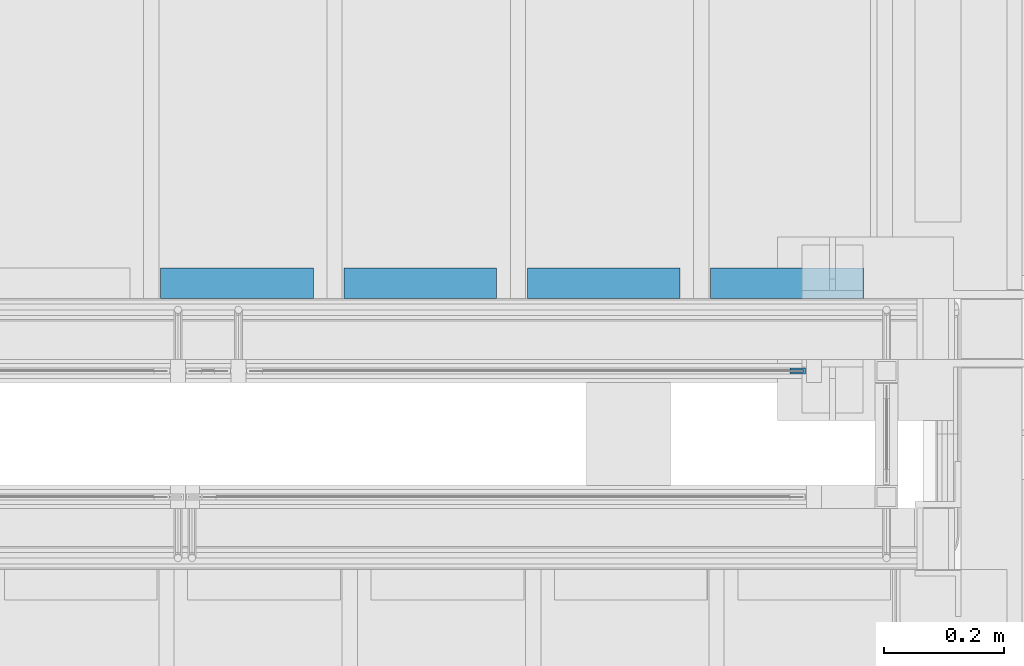
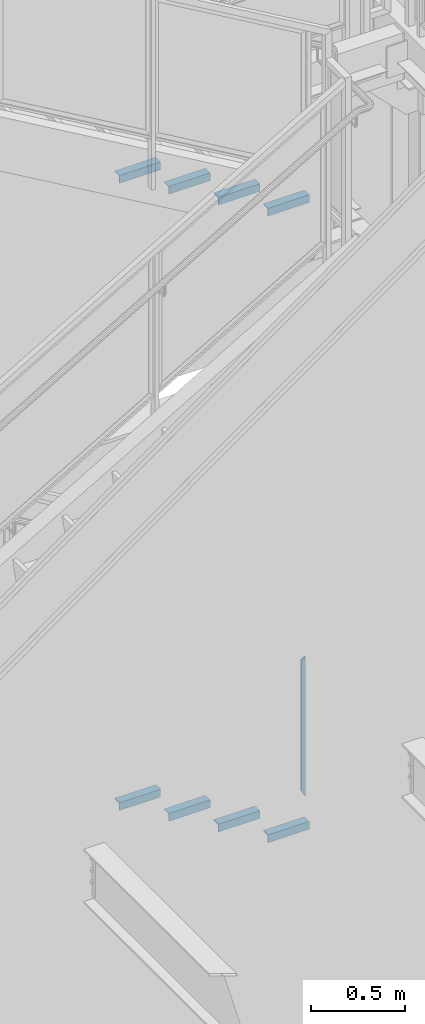
# One storey, part 941 of 1179: 9 beams, 3 elements without a shape of their own.
"""IFC2X3 building model written with IfcOpenShell, lengths in millimetres."""

import ifcopenshell
import ifcopenshell.guid

model = None  # the IFC model being written
_history = None  # IfcOwnerHistory: only IFC2X3 demands one
_inside = {}  # id of a spatial element -> (the spatial element, [elements in it])
_under = {}  # id of a project, library or spatial element -> (it, [spatial elements below it])
_declared = {}  # id of a project -> (the project, [libraries it declares])
_typed = {}  # id of a type object -> (the type object, [elements of that type])
_made_of = {}  # id of a material, layer set ... -> (it, [elements and type objects made of it])


def new_model(schema):
    """Start an empty IFC model of exactly this schema.

    Asked for "IFC4X3", IfcOpenShell would pick the latest addendum, in which some entities
    have other attributes; the version numbers below select the first issue.
    IFC2X3 requires an IfcOwnerHistory on every rooted entity: one is made here for all.
    """
    global model, _history
    if schema == "IFC4X3":
        model = ifcopenshell.file(schema_version=(4, 3, 0, 0))
    else:
        model = ifcopenshell.file(schema=schema)
    _inside.clear()
    _under.clear()
    _declared.clear()
    _typed.clear()
    _made_of.clear()
    _history = None
    if model.schema == "IFC2X3":
        org = make("IfcOrganization", Name="unknown")
        user = make(
            "IfcPersonAndOrganization",
            ThePerson=make("IfcPerson", FamilyName="unknown"),
            TheOrganization=org,
        )
        app = make(
            "IfcApplication",
            ApplicationDeveloper=org,
            Version="unknown",
            ApplicationFullName="unknown",
            ApplicationIdentifier="unknown",
        )
        _history = make(
            "IfcOwnerHistory",
            OwningUser=user,
            OwningApplication=app,
            ChangeAction="ADDED",
            CreationDate=0,
        )
    return model


def make(cls, **values):
    """One entity of the class cls with the attributes given. An attribute that is None is left unset."""
    return model.create_entity(
        cls, **{name: value for name, value in values.items() if value is not None}
    )


def rooted(cls, **values):
    """An entity with a GlobalId (a new one), such as an element, a storey or a relation."""
    return make(cls, GlobalId=ifcopenshell.guid.new(), OwnerHistory=_history, **values)


def si_unit(unit_type, name, prefix=None):
    """IfcSIUnit, for example si_unit("LENGTHUNIT", "METRE", prefix="MILLI")."""
    return make("IfcSIUnit", UnitType=unit_type, Prefix=prefix, Name=name)


def assignment(units):
    """IfcUnitAssignment: the units of a project."""
    return None if units is None else make("IfcUnitAssignment", Units=units)


def point(xyz):
    """IfcCartesianPoint."""
    return None if xyz is None else make("IfcCartesianPoint", Coordinates=xyz)


def direction(xyz):
    """IfcDirection."""
    return None if xyz is None else make("IfcDirection", DirectionRatios=xyz)


def frame(location, z_axis=None, x_axis=None):
    """IfcAxis2Placement3D, a coordinate frame: its origin and axes. An axis left out is left unset."""
    return make(
        "IfcAxis2Placement3D",
        Location=point(location),
        Axis=direction(z_axis),
        RefDirection=direction(x_axis),
    )


def origin_with_axes():
    """The frame at (0, 0, 0) with the z axis (0, 0, 1) and the x axis (1, 0, 0) written out."""
    return frame((0.0, 0.0, 0.0), z_axis=(0.0, 0.0, 1.0), x_axis=(1.0, 0.0, 0.0))


def place(relative_to, where):
    """IfcLocalPlacement: puts the frame where relative to a parent placement (None: the world)."""
    return make(
        "IfcLocalPlacement", PlacementRelTo=relative_to, RelativePlacement=where
    )


def context(
    kind, dimensions, precision=None, world=None, true_north=None, identifier=None
):
    """IfcGeometricRepresentationContext, for example the 3D "Model" context."""
    return make(
        "IfcGeometricRepresentationContext",
        ContextIdentifier=identifier,
        ContextType=kind,
        CoordinateSpaceDimension=dimensions,
        Precision=precision,
        WorldCoordinateSystem=world,
        TrueNorth=true_north,
    )


def subcontext(parent, identifier, kind, view, scale=None):
    """IfcGeometricRepresentationSubContext, for example "Body" below "Model"."""
    return make(
        "IfcGeometricRepresentationSubContext",
        ContextIdentifier=identifier,
        ContextType=kind,
        ParentContext=parent,
        TargetScale=scale,
        TargetView=view,
    )


def project(units=None, contexts=None):
    """IfcProject with its units and contexts."""
    return rooted(
        "IfcProject",
        Name="project",
        RepresentationContexts=contexts,
        UnitsInContext=assignment(units),
    )


def spatial(cls, under=None, at=None, **own):
    """A site, building, storey or space (cls), placed at a placement, below another one or the project."""
    s = rooted(cls, ObjectPlacement=at, **own)
    if under is not None:
        _under.setdefault(under.id(), (under, []))[1].append(s)
    return s


def faces_of(points, faces, orient=None, outer=None):
    """IfcFace entities. A face is a list of loops; a loop is a list of indices into points, from 0.

    orient and outer hold one flag for each loop. By default every Orientation is true, the
    first loop of a face is its IfcFaceOuterBound and the others are IfcFaceBound.
    """
    made = []
    for i, loops in enumerate(faces):
        bounds = []
        for j, loop in enumerate(loops):
            is_outer = j == 0 if outer is None else outer[i][j]
            bounds.append(
                make(
                    "IfcFaceOuterBound" if is_outer else "IfcFaceBound",
                    Bound=make("IfcPolyLoop", Polygon=[points[k] for k in loop]),
                    Orientation=True if orient is None else orient[i][j],
                )
            )
        made.append(make("IfcFace", Bounds=bounds))
    return made


def faceted_brep(points, faces, orient=None, outer=None, voids=None):
    """IfcFacetedBrep: a solid bounded by flat faces; with voids (closed shells), ...WithVoids."""
    shared = [point(p) for p in points]
    hull = make("IfcClosedShell", CfsFaces=faces_of(shared, faces, orient, outer))
    if voids is None:
        return make("IfcFacetedBrep", Outer=hull)
    return make(
        "IfcFacetedBrepWithVoids",
        Outer=hull,
        Voids=[
            make(cls, CfsFaces=faces_of(shared, fs, o, b)) for cls, fs, o, b in voids
        ],
    )


def shape(context_of_items, identifier, shape_type, items):
    """IfcShapeRepresentation: the items that make up one representation, for example the "Body"."""
    return make(
        "IfcShapeRepresentation",
        ContextOfItems=context_of_items,
        RepresentationIdentifier=identifier,
        RepresentationType=shape_type,
        Items=items,
    )


def material(Name=None, Category=None):
    """IfcMaterial."""
    return make("IfcMaterial", Name=Name, Category=Category)


def made_of(thing, what):
    """Note that an element or type object is made of a material, layer set ...; save() writes the relation."""
    if what is not None:
        _made_of.setdefault(what.id(), (what, []))[1].append(thing)
    return thing


def type_object(cls, material=None, **own):
    """A type object (cls), such as IfcWallType, which elements share."""
    return made_of(rooted(cls, **own), material)


def element(
    cls,
    number,
    at=None,
    inside=None,
    cuts=None,
    type_object=None,
    material=None,
    context=None,
    identifier="Body",
    shape_type=None,
    held_by="IfcProductDefinitionShape",
    body=None,
    shapes=None,
    **own,
):
    """One element of the class cls, such as IfcWall. Its Tag is "e" and its number.

    at: its placement. inside: the storey or other place that contains it. cuts: it is an
    opening in that element (IfcRelVoidsElement). A single representation is given by context,
    identifier, shape_type and body (its items); several are given by shapes. held_by: the class
    of the entity that holds the representations. save() writes the other relations.
    """
    e = rooted(cls, Tag="e%d" % number, ObjectPlacement=at, **own)
    if body is not None:
        shapes = [shape(context, identifier, shape_type, body)]
    if shapes is not None:
        e.Representation = make(held_by, Representations=shapes)
    if inside is not None:
        _inside.setdefault(inside.id(), (inside, []))[1].append(e)
    if cuts is not None:
        rooted(
            "IfcRelVoidsElement", RelatingBuildingElement=cuts, RelatedOpeningElement=e
        )
    if type_object is not None:
        _typed.setdefault(type_object.id(), (type_object, []))[1].append(e)
    return made_of(e, material)


def aggregate(whole, parts):
    """IfcRelAggregates: a whole, such as a stair, and the parts it consists of."""
    return rooted("IfcRelAggregates", RelatingObject=whole, RelatedObjects=parts)


def save(model, path):
    """Write the relations noted so far, then the file.

    IfcRelAggregates (storeys below a building ...), IfcRelContainedInSpatialStructure (elements
    in a storey), IfcRelDefinesByType, IfcRelAssociatesMaterial and IfcRelDeclares: one each for
    every whole, place, type object, material and project.
    """
    for whole, parts in _under.values():
        aggregate(whole, parts)
    for where, things in _inside.values():
        rooted(
            "IfcRelContainedInSpatialStructure",
            RelatedElements=things,
            RelatingStructure=where,
        )
    for kind, things in _typed.values():
        rooted("IfcRelDefinesByType", RelatedObjects=things, RelatingType=kind)
    for what, things in _made_of.values():
        rooted("IfcRelAssociatesMaterial", RelatedObjects=things, RelatingMaterial=what)
    for by, libraries in _declared.values():
        rooted("IfcRelDeclares", RelatingContext=by, RelatedDefinitions=libraries)
    model.write(path)


model = new_model("IFC2X3")

# Units and contexts
model_context = context("Model", 3, precision=1e-05, world=origin_with_axes())
body_context = subcontext(model_context, "Body", "Model", "MODEL_VIEW")
ifc_project = project(units=[si_unit("LENGTHUNIT", "METRE", prefix="MILLI"), si_unit("AREAUNIT", "SQUARE_METRE"), si_unit("VOLUMEUNIT", "CUBIC_METRE"), si_unit("MASSUNIT", "GRAM", prefix="KILO"), si_unit("TIMEUNIT", "SECOND"), si_unit("PLANEANGLEUNIT", "RADIAN"), si_unit("SOLIDANGLEUNIT", "STERADIAN"), si_unit("THERMODYNAMICTEMPERATUREUNIT", "DEGREE_CELSIUS"), si_unit("LUMINOUSINTENSITYUNIT", "LUMEN")], contexts=[model_context])

# Site, building, storey
site_placement = place(None, origin_with_axes())
site = spatial("IfcSite", under=ifc_project, at=site_placement, CompositionType="ELEMENT")
building_placement = place(site_placement, origin_with_axes())
building = spatial("IfcBuilding", under=site, at=building_placement, Name="Undefined", CompositionType="ELEMENT")
storey_placement = place(building_placement, origin_with_axes())
storey = spatial("IfcBuildingStorey", under=building, at=storey_placement, Name="Undefined", CompositionType="ELEMENT", Elevation=0.0)

# Assembly, beam
assembly_1_placement = place(storey_placement, origin_with_axes())
assembly_1 = element("IfcElementAssembly", 1, at=assembly_1_placement, inside=storey, Name="GUARDRAIL", AssemblyPlace="NOTDEFINED", PredefinedType="RIGID_FRAME")
ifc_material_1 = material(Name="STEEL/BUY-OUT")
beam_type_1 = type_object("IfcBeamType", PredefinedType="NOTDEFINED")
beam_1_placement = place(assembly_1_placement, frame((22683.7873880621, 39677.9751661867, 2966.37570658179), z_axis=(0.0, 0.0, -1.0), x_axis=(1.0, 0.0, 0.0)))
beam_1 = element("IfcBeam", 2, at=beam_1_placement, type_object=beam_type_1, material=ifc_material_1, Name="U-EDGE", context=body_context, shape_type="Brep", body=[
    faceted_brep([(0.0, 1.58750000000146, 410.762302941614), (25.400000000016, 1.58750000000146, 454.819), (25.400000000016, 1.58750000000146, -454.819), (0.0, 1.58750000000146, -440.175144311391), (0.0, -1.58750000000146, 410.762302941614), (0.0, -1.58750000000146, -440.175144311391), (22.2250000000131, -1.58750000000146, 449.311912867583), (22.2250000000131, -1.58750000000146, -452.988518038564), (22.2250000000131, -4.76249999999709, 449.311912867583), (22.2250000000131, -4.76249999999709, -452.988518038564), (2.91038304567337e-11, -4.76249999999709, 410.762302941664), (2.91038304567337e-11, -4.76249999999709, -440.175144311408), (2.91038304567337e-11, -7.9375, 410.762302941664), (2.91038304567337e-11, -7.9375, -440.175144311408), (25.400000000016, -7.9375, 454.819), (25.400000000016, -7.9375, -454.819)], [[[0, 1, 2, 3]], [[4, 0, 3, 5]], [[6, 4, 5, 7]], [[8, 6, 7, 9]], [[10, 8, 9, 11]], [[12, 10, 11, 13]], [[14, 12, 13, 15]], [[11, 9, 7, 5, 3, 2, 15, 13]], [[1, 14, 15, 2]], [[0, 4, 6, 8, 10, 12, 14, 1]]]),
])
aggregate(assembly_1, [beam_1])

# Assembly, beams
assembly_2_placement = place(storey_placement, origin_with_axes())
assembly_2 = element("IfcElementAssembly", 3, at=assembly_2_placement, inside=storey, Name="STAIR", AssemblyPlace="NOTDEFINED", PredefinedType="RIGID_FRAME")
ifc_material_2 = material(Name="STEEL/A36")
beam_type_2 = type_object("IfcBeamType", Name="L2X2X3/16", PredefinedType="NOTDEFINED")
beam_2_placement = place(assembly_2_placement, frame((21891.232173485, 39827.2000000314, 2744.85363313538), z_axis=(0.0, 1.0, 0.0), x_axis=(-1.0, 0.0, 0.0)))
beam_2 = element("IfcBeam", 4, at=beam_2_placement, type_object=beam_type_2, material=ifc_material_2, Name="ANGLE", ObjectType="L2X2X3/16", context=body_context, shape_type="Brep", body=[
    faceted_brep([(0.0, 25.3999999999996, -25.4000000000015), (0.0, 25.3999999999996, 25.4000000000015), (254.0, 25.3999999999996, 25.4000000000001), (254.0, 25.3999999999996, -25.4000000000001), (0.0, 20.6374999999998, 25.4000000000015), (254.0, 20.6374999999998, 25.4000000000001), (0.0, 20.6374999999998, -20.6374999999971), (254.0, 20.6374999999998, -20.6374999999998), (0.0, -25.3999999999996, -20.6374999999971), (254.0, -25.3999999999996, -20.6374999999998), (0.0, -25.3999999999996, -25.4000000000015), (254.0, -25.3999999999996, -25.4000000000001)], [[[0, 1, 2, 3]], [[1, 4, 5, 2]], [[4, 6, 7, 5]], [[6, 8, 9, 7]], [[8, 10, 11, 9]], [[10, 0, 3, 11]], [[5, 7, 9, 11, 3, 2]], [[10, 8, 6, 4, 1, 0]]]),
])
beam_3_placement = place(assembly_2_placement, frame((22196.0321734775, 39827.2000000292, 2568.37654985167), z_axis=(0.0, 1.0, 0.0), x_axis=(-1.0, 0.0, 0.0)))
beam_3 = element("IfcBeam", 5, at=beam_3_placement, type_object=beam_type_2, material=ifc_material_2, Name="ANGLE", ObjectType="L2X2X3/16", context=body_context, shape_type="Brep", body=[
    faceted_brep([(0.0, 25.3999999999996, -25.4000000000015), (0.0, 25.3999999999996, 25.4000000000015), (254.0, 25.3999999999996, 25.4000000000001), (254.0, 25.3999999999996, -25.4000000000001), (0.0, 20.6374999999998, 25.4000000000015), (254.0, 20.6374999999998, 25.4000000000001), (0.0, 20.6374999999998, -20.6374999999971), (254.0, 20.6374999999998, -20.6374999999998), (0.0, -25.3999999999996, -20.6374999999971), (254.0, -25.3999999999996, -20.6374999999998), (0.0, -25.3999999999996, -25.4000000000015), (254.0, -25.3999999999996, -25.4000000000001)], [[[0, 1, 2, 3]], [[1, 4, 5, 2]], [[4, 6, 7, 5]], [[6, 8, 9, 7]], [[8, 10, 11, 9]], [[10, 0, 3, 11]], [[5, 7, 9, 11, 3, 2]], [[10, 8, 6, 4, 1, 0]]]),
])
beam_4_placement = place(assembly_2_placement, frame((22500.8321734701, 39827.2000000269, 2391.89946656796), z_axis=(0.0, 1.0, 0.0), x_axis=(-1.0, 0.0, 0.0)))
beam_4 = element("IfcBeam", 6, at=beam_4_placement, type_object=beam_type_2, material=ifc_material_2, Name="ANGLE", ObjectType="L2X2X3/16", context=body_context, shape_type="Brep", body=[
    faceted_brep([(0.0, 25.3999999999996, -25.4000000000015), (0.0, 25.3999999999996, 25.4000000000015), (254.0, 25.3999999999996, 25.4000000000001), (254.0, 25.3999999999996, -25.4000000000001), (0.0, 20.6374999999998, 25.4000000000015), (254.0, 20.6374999999998, 25.4000000000001), (0.0, 20.6374999999998, -20.6374999999971), (254.0, 20.6374999999998, -20.6374999999998), (0.0, -25.3999999999996, -20.6374999999971), (254.0, -25.3999999999996, -20.6374999999998), (0.0, -25.3999999999996, -25.4000000000015), (254.0, -25.3999999999996, -25.4000000000001)], [[[0, 1, 2, 3]], [[1, 4, 5, 2]], [[4, 6, 7, 5]], [[6, 8, 9, 7]], [[8, 10, 11, 9]], [[10, 0, 3, 11]], [[5, 7, 9, 11, 3, 2]], [[10, 8, 6, 4, 1, 0]]]),
])
beam_5_placement = place(assembly_2_placement, frame((22805.6321734627, 39827.2000000247, 2215.42238328425), z_axis=(0.0, 1.0, 0.0), x_axis=(-1.0, 0.0, 0.0)))
beam_5 = element("IfcBeam", 7, at=beam_5_placement, type_object=beam_type_2, material=ifc_material_2, Name="ANGLE", ObjectType="L2X2X3/16", context=body_context, shape_type="Brep", body=[
    faceted_brep([(0.0, 25.3999999999996, -25.4000000000015), (0.0, 25.3999999999996, 25.4000000000015), (254.0, 25.3999999999996, 25.4000000000001), (254.0, 25.3999999999996, -25.4000000000001), (0.0, 20.6374999999998, 25.4000000000015), (254.0, 20.6374999999998, 25.4000000000001), (0.0, 20.6374999999998, -20.6374999999971), (254.0, 20.6374999999998, -20.6374999999998), (0.0, -25.3999999999996, -20.6374999999971), (254.0, -25.3999999999996, -20.6374999999998), (0.0, -25.3999999999996, -25.4000000000015), (254.0, -25.3999999999996, -25.4000000000001)], [[[0, 1, 2, 3]], [[1, 4, 5, 2]], [[4, 6, 7, 5]], [[6, 8, 9, 7]], [[8, 10, 11, 9]], [[10, 0, 3, 11]], [[5, 7, 9, 11, 3, 2]], [[10, 8, 6, 4, 1, 0]]]),
])
aggregate(assembly_2, [beam_2, beam_3, beam_4, beam_5])

assembly_3_placement = place(storey_placement, origin_with_axes())
assembly_3 = element("IfcElementAssembly", 8, at=assembly_3_placement, inside=storey, Name="STAIR", AssemblyPlace="NOTDEFINED", PredefinedType="RIGID_FRAME")
beam_6_placement = place(assembly_3_placement, frame((21891.2869677846, 39827.2000000125, 6823.67030000811), z_axis=(0.0, 1.0, 0.0), x_axis=(-1.0, 0.0, 0.0)))
beam_6 = element("IfcBeam", 9, at=beam_6_placement, type_object=beam_type_2, material=ifc_material_2, Name="ANGLE", ObjectType="L2X2X3/16", context=body_context, shape_type="Brep", body=[
    faceted_brep([(0.0, 25.3999999999996, -25.4000000000015), (0.0, 25.3999999999996, 25.4000000000015), (254.0, 25.3999999999996, 25.4000000000001), (254.0, 25.3999999999996, -25.4000000000001), (0.0, 20.6374999999998, 25.4000000000015), (254.0, 20.6374999999998, 25.4000000000001), (0.0, 20.6374999999998, -20.6374999999971), (254.0, 20.6374999999998, -20.6374999999998), (0.0, -25.3999999999996, -20.6374999999971), (254.0, -25.3999999999996, -20.6374999999998), (0.0, -25.3999999999996, -25.4000000000015), (254.0, -25.3999999999996, -25.4000000000001)], [[[0, 1, 2, 3]], [[1, 4, 5, 2]], [[4, 6, 7, 5]], [[6, 8, 9, 7]], [[8, 10, 11, 9]], [[10, 0, 3, 11]], [[5, 7, 9, 11, 3, 2]], [[10, 8, 6, 4, 1, 0]]]),
])
beam_7_placement = place(assembly_3_placement, frame((22196.0869675326, 39827.2000000125, 6645.87030000811), z_axis=(0.0, 1.0, 0.0), x_axis=(-1.0, 0.0, 0.0)))
beam_7 = element("IfcBeam", 10, at=beam_7_placement, type_object=beam_type_2, material=ifc_material_2, Name="ANGLE", ObjectType="L2X2X3/16", context=body_context, shape_type="Brep", body=[
    faceted_brep([(0.0, 25.3999999999996, -25.4000000000015), (0.0, 25.3999999999996, 25.4000000000015), (254.0, 25.3999999999996, 25.4000000000001), (254.0, 25.3999999999996, -25.4000000000001), (0.0, 20.6374999999998, 25.4000000000015), (254.0, 20.6374999999998, 25.4000000000001), (0.0, 20.6374999999998, -20.6374999999971), (254.0, 20.6374999999998, -20.6374999999998), (0.0, -25.3999999999996, -20.6374999999971), (254.0, -25.3999999999996, -20.6374999999998), (0.0, -25.3999999999996, -25.4000000000015), (254.0, -25.3999999999996, -25.4000000000001)], [[[0, 1, 2, 3]], [[1, 4, 5, 2]], [[4, 6, 7, 5]], [[6, 8, 9, 7]], [[8, 10, 11, 9]], [[10, 0, 3, 11]], [[5, 7, 9, 11, 3, 2]], [[10, 8, 6, 4, 1, 0]]]),
])
beam_8_placement = place(assembly_3_placement, frame((22500.8869672805, 39827.2000000125, 6468.07030000811), z_axis=(0.0, 1.0, 0.0), x_axis=(-1.0, 0.0, 0.0)))
beam_8 = element("IfcBeam", 11, at=beam_8_placement, type_object=beam_type_2, material=ifc_material_2, Name="ANGLE", ObjectType="L2X2X3/16", context=body_context, shape_type="Brep", body=[
    faceted_brep([(0.0, 25.3999999999996, -25.4000000000015), (0.0, 25.3999999999996, 25.4000000000015), (254.0, 25.3999999999996, 25.4000000000001), (254.0, 25.3999999999996, -25.4000000000001), (0.0, 20.6374999999998, 25.4000000000015), (254.0, 20.6374999999998, 25.4000000000001), (0.0, 20.6374999999998, -20.6374999999971), (254.0, 20.6374999999998, -20.6374999999998), (0.0, -25.3999999999996, -20.6374999999971), (254.0, -25.3999999999996, -20.6374999999998), (0.0, -25.3999999999996, -25.4000000000015), (254.0, -25.3999999999996, -25.4000000000001)], [[[0, 1, 2, 3]], [[1, 4, 5, 2]], [[4, 6, 7, 5]], [[6, 8, 9, 7]], [[8, 10, 11, 9]], [[10, 0, 3, 11]], [[5, 7, 9, 11, 3, 2]], [[10, 8, 6, 4, 1, 0]]]),
])
beam_9_placement = place(assembly_3_placement, frame((22805.6869670285, 39827.2000000125, 6290.27030000811), z_axis=(0.0, 1.0, 0.0), x_axis=(-1.0, 0.0, 0.0)))
beam_9 = element("IfcBeam", 12, at=beam_9_placement, type_object=beam_type_2, material=ifc_material_2, Name="ANGLE", ObjectType="L2X2X3/16", context=body_context, shape_type="Brep", body=[
    faceted_brep([(0.0, 25.3999999999996, -25.4000000000015), (0.0, 25.3999999999996, 25.4000000000015), (254.0, 25.3999999999996, 25.4000000000001), (254.0, 25.3999999999996, -25.4000000000001), (0.0, 20.6374999999998, 25.4000000000015), (254.0, 20.6374999999998, 25.4000000000001), (0.0, 20.6374999999998, -20.6374999999971), (254.0, 20.6374999999998, -20.6374999999998), (0.0, -25.3999999999996, -20.6374999999971), (254.0, -25.3999999999996, -20.6374999999998), (0.0, -25.3999999999996, -25.4000000000015), (254.0, -25.3999999999996, -25.4000000000001)], [[[0, 1, 2, 3]], [[1, 4, 5, 2]], [[4, 6, 7, 5]], [[6, 8, 9, 7]], [[8, 10, 11, 9]], [[10, 0, 3, 11]], [[5, 7, 9, 11, 3, 2]], [[10, 8, 6, 4, 1, 0]]]),
])
aggregate(assembly_3, [beam_6, beam_7, beam_8, beam_9])

save(model, "model.ifc")
